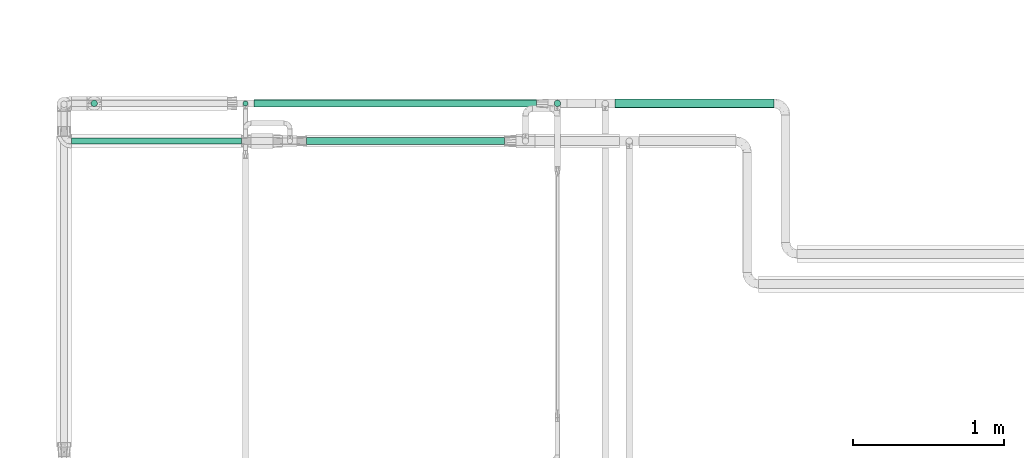
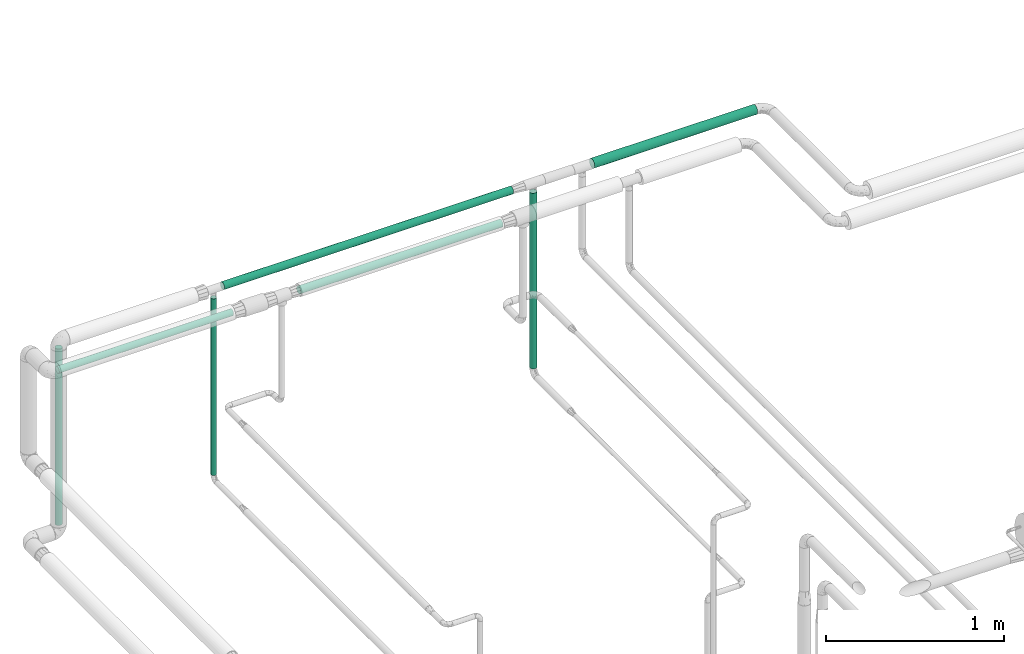
# One storey, part 526 of 827: 7 flow segments.
"""IFC2X3 building model written with IfcOpenShell, lengths in millimetres."""

from ifc_helpers import new_model, entity, si_unit, converted_unit, derived_unit, direction, frame, origin, origin_2d_with_axis, place, context, subcontext, project, spatial, circle, extrude, type_object, element, save


model = new_model("IFC2X3")

# Units and contexts
model_context = context("Model", 3, precision=0.01, world=origin(), true_north=direction((6.12303176911189e-17, 1.0)))
body_context = subcontext(model_context, "Body", "Model", "MODEL_VIEW")
ifc_project = project(units=[si_unit("LENGTHUNIT", "METRE", prefix="MILLI"), si_unit("AREAUNIT", "SQUARE_METRE"), si_unit("VOLUMEUNIT", "CUBIC_METRE"), converted_unit("PLANEANGLEUNIT", "DEGREE", entity("IfcRatioMeasure", 0.0174532925199433), si_unit("PLANEANGLEUNIT", "RADIAN"), dimensions=[0, 0, 0, 0, 0, 0, 0]), si_unit("MASSUNIT", "GRAM", prefix="KILO"), derived_unit("MASSDENSITYUNIT", [(si_unit("MASSUNIT", "GRAM", prefix="KILO"), 1), (si_unit("LENGTHUNIT", "METRE"), -3)]), derived_unit("MOMENTOFINERTIAUNIT", [(si_unit("LENGTHUNIT", "METRE"), 4)]), si_unit("TIMEUNIT", "SECOND"), si_unit("FREQUENCYUNIT", "HERTZ"), si_unit("THERMODYNAMICTEMPERATUREUNIT", "DEGREE_CELSIUS"), derived_unit("THERMALTRANSMITTANCEUNIT", [(si_unit("MASSUNIT", "GRAM", prefix="KILO"), 1), (si_unit("THERMODYNAMICTEMPERATUREUNIT", "KELVIN"), -1), (si_unit("TIMEUNIT", "SECOND"), -3)]), derived_unit("VOLUMETRICFLOWRATEUNIT", [(si_unit("LENGTHUNIT", "METRE"), 3), (si_unit("TIMEUNIT", "SECOND"), -1)]), derived_unit("MASSFLOWRATEUNIT", [(si_unit("MASSUNIT", "GRAM", prefix="KILO"), 1), (si_unit("TIMEUNIT", "SECOND"), -1)]), derived_unit("ROTATIONALFREQUENCYUNIT", [(si_unit("TIMEUNIT", "SECOND"), -1)]), si_unit("ELECTRICCURRENTUNIT", "AMPERE"), si_unit("ELECTRICVOLTAGEUNIT", "VOLT"), si_unit("POWERUNIT", "WATT"), si_unit("FORCEUNIT", "NEWTON", prefix="KILO"), si_unit("ILLUMINANCEUNIT", "LUX"), si_unit("LUMINOUSFLUXUNIT", "LUMEN"), si_unit("LUMINOUSINTENSITYUNIT", "CANDELA"), derived_unit("USERDEFINED", [(si_unit("MASSUNIT", "GRAM", prefix="KILO"), -1), (si_unit("LENGTHUNIT", "METRE"), -2), (si_unit("TIMEUNIT", "SECOND"), 3), (si_unit("LUMINOUSFLUXUNIT", "LUMEN"), 1)]), derived_unit("LINEARVELOCITYUNIT", [(si_unit("LENGTHUNIT", "METRE"), 1), (si_unit("TIMEUNIT", "SECOND"), -1)]), si_unit("PRESSUREUNIT", "PASCAL"), derived_unit("USERDEFINED", [(si_unit("LENGTHUNIT", "METRE"), -2), (si_unit("MASSUNIT", "GRAM", prefix="KILO"), 1), (si_unit("TIMEUNIT", "SECOND"), -2)]), derived_unit("LINEARFORCEUNIT", [(si_unit("MASSUNIT", "GRAM", prefix="KILO"), 1), (si_unit("LENGTHUNIT", "METRE"), 1), (si_unit("TIMEUNIT", "SECOND"), -2), (si_unit("LENGTHUNIT", "METRE"), -1)]), derived_unit("PLANARFORCEUNIT", [(si_unit("MASSUNIT", "GRAM", prefix="KILO"), 1), (si_unit("LENGTHUNIT", "METRE"), 1), (si_unit("TIMEUNIT", "SECOND"), -2), (si_unit("LENGTHUNIT", "METRE"), -2)])], contexts=[model_context])

# Site, building, storey
site_placement = place(None, origin())
site = spatial("IfcSite", under=ifc_project, at=site_placement, CompositionType="ELEMENT")
building_placement = place(site_placement, origin())
building = spatial("IfcBuilding", under=site, at=building_placement, CompositionType="ELEMENT")
storey_placement = place(building_placement, frame((0.0, 0.0, 28200.0)))
storey = spatial("IfcBuildingStorey", under=building, at=storey_placement, Name="08", CompositionType="ELEMENT", Elevation=28200.0)

# Flow segments
pipe_segment_type = type_object("IfcPipeSegmentType", PredefinedType="NOTDEFINED")
flow_segment_1_placement = place(storey_placement, frame((15665.55, 18981.87, 2968.4)))
element("IfcFlowSegment", 1, at=flow_segment_1_placement, inside=storey, type_object=pipe_segment_type, context=body_context, shape_type="SweptSolid", body=[
    extrude(circle(Radius=30.0, at=origin_2d_with_axis()), frame((0.0, 31.6, 31.6), z_axis=(1.0, 0.0, 0.0), x_axis=(0.0, -1.0, 0.0)), (0.0, 0.0, 1.0), 1057.5101280839),
])
flow_segment_2_placement = place(storey_placement, frame((12183.2, 18990.72, 1742.27)))
element("IfcFlowSegment", 2, at=flow_segment_2_placement, inside=storey, type_object=pipe_segment_type, context=body_context, shape_type="SweptSolid", body=[
    extrude(circle(Radius=21.15, at=origin_2d_with_axis()), frame((22.75, 22.75, 0.0)), (0.0, 0.0, 1.0), 1209.73020064811),
])
flow_segment_3_placement = place(storey_placement, frame((15260.77, 18990.72, 1738.73)))
element("IfcFlowSegment", 3, at=flow_segment_3_placement, inside=storey, type_object=pipe_segment_type, context=body_context, shape_type="SweptSolid", body=[
    extrude(circle(Radius=21.15, at=origin_2d_with_axis()), frame((22.75, 22.75, 0.0)), (0.0, 0.0, 1.0), 1204.26645085389),
])
flow_segment_4_placement = place(storey_placement, frame((13192.62, 18994.45, 1730.66)))
element("IfcFlowSegment", 4, at=flow_segment_4_placement, inside=storey, type_object=pipe_segment_type, context=body_context, shape_type="SweptSolid", body=[
    extrude(circle(Radius=16.75, at=origin_2d_with_axis()), frame((18.35, 18.35, 0.0)), (0.0, 0.0, 1.0), 1211.39855189052),
])
flow_segment_5_placement = place(storey_placement, frame((13267.97, 18987.87, 2974.4)))
element("IfcFlowSegment", 5, at=flow_segment_5_placement, inside=storey, type_object=pipe_segment_type, context=body_context, shape_type="SweptSolid", body=[
    extrude(circle(Radius=24.0, at=origin_2d_with_axis()), frame((0.0, 25.6, 25.6), z_axis=(1.0, 0.0, 0.0), x_axis=(0.0, -1.0, 0.0)), (0.0, 0.0, 1.0), 1875.54250703299),
])
flow_segment_6_placement = place(storey_placement, frame((13617.95, 18737.38, 2974.4)))
element("IfcFlowSegment", 6, at=flow_segment_6_placement, inside=storey, type_object=pipe_segment_type, context=body_context, shape_type="SweptSolid", body=[
    extrude(circle(Radius=24.0, at=origin_2d_with_axis()), frame((0.0, 25.6, 25.6), z_axis=(1.0, 0.0, 0.0), x_axis=(0.0, -1.0, 0.0)), (0.0, 0.0, 1.0), 1312.94608002415),
])
flow_segment_7_placement = place(storey_placement, frame((12053.46, 18740.23, 2977.25)))
element("IfcFlowSegment", 7, at=flow_segment_7_placement, inside=storey, type_object=pipe_segment_type, context=body_context, shape_type="SweptSolid", body=[
    extrude(circle(Radius=21.15, at=origin_2d_with_axis()), frame((0.0, 22.75, 22.75), z_axis=(1.0, 0.0, 0.0), x_axis=(0.0, -1.0, 0.0)), (0.0, 0.0, 1.0), 1131.4301613299),
])

save(model, "model.ifc")
